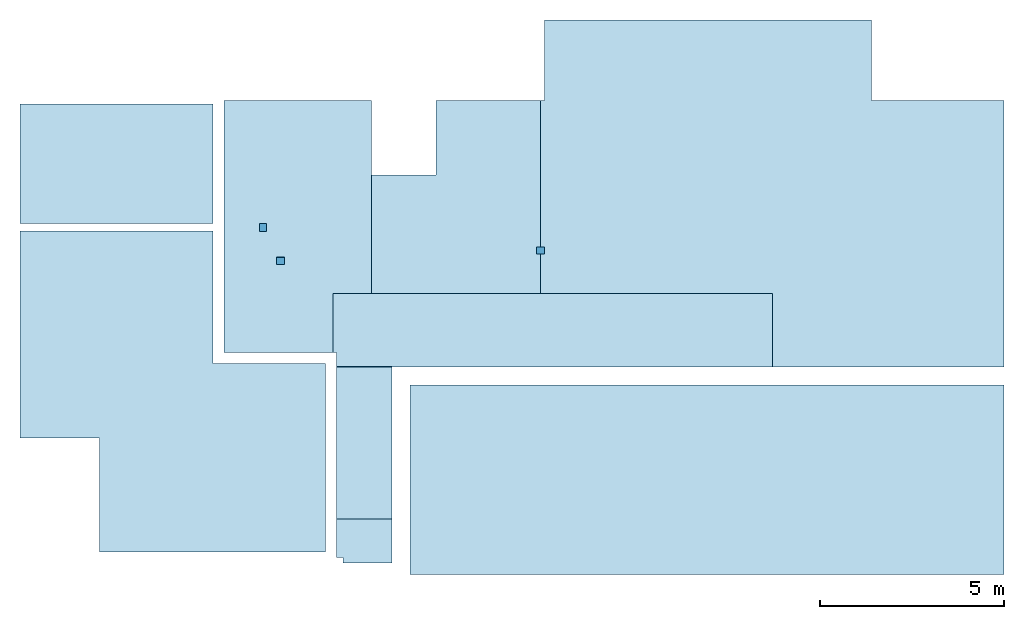
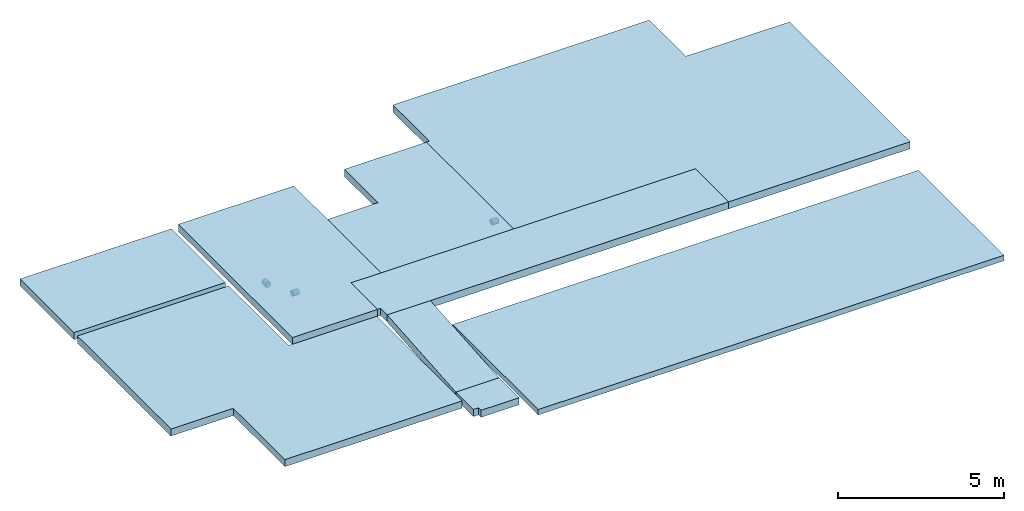
# One storey: 9 slabs, 3 beams, 12 elements without a shape of their own.
"""IFC2X3 building model written with IfcOpenShell, lengths in millimetres."""

import ifcopenshell
import ifcopenshell.guid

model = None  # the IFC model being written
_history = None  # IfcOwnerHistory: only IFC2X3 demands one
_inside = {}  # id of a spatial element -> (the spatial element, [elements in it])
_under = {}  # id of a project, library or spatial element -> (it, [spatial elements below it])
_declared = {}  # id of a project -> (the project, [libraries it declares])
_typed = {}  # id of a type object -> (the type object, [elements of that type])
_made_of = {}  # id of a material, layer set ... -> (it, [elements and type objects made of it])


def new_model(schema):
    """Start an empty IFC model of exactly this schema.

    Asked for "IFC4X3", IfcOpenShell would pick the latest addendum, in which some entities
    have other attributes; the version numbers below select the first issue.
    IFC2X3 requires an IfcOwnerHistory on every rooted entity: one is made here for all.
    """
    global model, _history
    if schema == "IFC4X3":
        model = ifcopenshell.file(schema_version=(4, 3, 0, 0))
    else:
        model = ifcopenshell.file(schema=schema)
    _inside.clear()
    _under.clear()
    _declared.clear()
    _typed.clear()
    _made_of.clear()
    _history = None
    if model.schema == "IFC2X3":
        org = make("IfcOrganization", Name="unknown")
        user = make(
            "IfcPersonAndOrganization",
            ThePerson=make("IfcPerson", FamilyName="unknown"),
            TheOrganization=org,
        )
        app = make(
            "IfcApplication",
            ApplicationDeveloper=org,
            Version="unknown",
            ApplicationFullName="unknown",
            ApplicationIdentifier="unknown",
        )
        _history = make(
            "IfcOwnerHistory",
            OwningUser=user,
            OwningApplication=app,
            ChangeAction="ADDED",
            CreationDate=0,
        )
    return model


def make(cls, **values):
    """One entity of the class cls with the attributes given. An attribute that is None is left unset."""
    return model.create_entity(
        cls, **{name: value for name, value in values.items() if value is not None}
    )


def rooted(cls, **values):
    """An entity with a GlobalId (a new one), such as an element, a storey or a relation."""
    return make(cls, GlobalId=ifcopenshell.guid.new(), OwnerHistory=_history, **values)


def si_unit(unit_type, name, prefix=None):
    """IfcSIUnit, for example si_unit("LENGTHUNIT", "METRE", prefix="MILLI")."""
    return make("IfcSIUnit", UnitType=unit_type, Prefix=prefix, Name=name)


def assignment(units):
    """IfcUnitAssignment: the units of a project."""
    return None if units is None else make("IfcUnitAssignment", Units=units)


def point(xyz):
    """IfcCartesianPoint."""
    return None if xyz is None else make("IfcCartesianPoint", Coordinates=xyz)


def direction(xyz):
    """IfcDirection."""
    return None if xyz is None else make("IfcDirection", DirectionRatios=xyz)


def frame(location, z_axis=None, x_axis=None):
    """IfcAxis2Placement3D, a coordinate frame: its origin and axes. An axis left out is left unset."""
    return make(
        "IfcAxis2Placement3D",
        Location=point(location),
        Axis=direction(z_axis),
        RefDirection=direction(x_axis),
    )


def origin_with_axes():
    """The frame at (0, 0, 0) with the z axis (0, 0, 1) and the x axis (1, 0, 0) written out."""
    return frame((0.0, 0.0, 0.0), z_axis=(0.0, 0.0, 1.0), x_axis=(1.0, 0.0, 0.0))


def place(relative_to, where):
    """IfcLocalPlacement: puts the frame where relative to a parent placement (None: the world)."""
    return make(
        "IfcLocalPlacement", PlacementRelTo=relative_to, RelativePlacement=where
    )


def context(
    kind, dimensions, precision=None, world=None, true_north=None, identifier=None
):
    """IfcGeometricRepresentationContext, for example the 3D "Model" context."""
    return make(
        "IfcGeometricRepresentationContext",
        ContextIdentifier=identifier,
        ContextType=kind,
        CoordinateSpaceDimension=dimensions,
        Precision=precision,
        WorldCoordinateSystem=world,
        TrueNorth=true_north,
    )


def subcontext(parent, identifier, kind, view, scale=None):
    """IfcGeometricRepresentationSubContext, for example "Body" below "Model"."""
    return make(
        "IfcGeometricRepresentationSubContext",
        ContextIdentifier=identifier,
        ContextType=kind,
        ParentContext=parent,
        TargetScale=scale,
        TargetView=view,
    )


def project(units=None, contexts=None):
    """IfcProject with its units and contexts."""
    return rooted(
        "IfcProject",
        Name="project",
        RepresentationContexts=contexts,
        UnitsInContext=assignment(units),
    )


def spatial(cls, under=None, at=None, **own):
    """A site, building, storey or space (cls), placed at a placement, below another one or the project."""
    s = rooted(cls, ObjectPlacement=at, **own)
    if under is not None:
        _under.setdefault(under.id(), (under, []))[1].append(s)
    return s


def faces_of(points, faces, orient=None, outer=None):
    """IfcFace entities. A face is a list of loops; a loop is a list of indices into points, from 0.

    orient and outer hold one flag for each loop. By default every Orientation is true, the
    first loop of a face is its IfcFaceOuterBound and the others are IfcFaceBound.
    """
    made = []
    for i, loops in enumerate(faces):
        bounds = []
        for j, loop in enumerate(loops):
            is_outer = j == 0 if outer is None else outer[i][j]
            bounds.append(
                make(
                    "IfcFaceOuterBound" if is_outer else "IfcFaceBound",
                    Bound=make("IfcPolyLoop", Polygon=[points[k] for k in loop]),
                    Orientation=True if orient is None else orient[i][j],
                )
            )
        made.append(make("IfcFace", Bounds=bounds))
    return made


def faceted_brep(points, faces, orient=None, outer=None, voids=None):
    """IfcFacetedBrep: a solid bounded by flat faces; with voids (closed shells), ...WithVoids."""
    shared = [point(p) for p in points]
    hull = make("IfcClosedShell", CfsFaces=faces_of(shared, faces, orient, outer))
    if voids is None:
        return make("IfcFacetedBrep", Outer=hull)
    return make(
        "IfcFacetedBrepWithVoids",
        Outer=hull,
        Voids=[
            make(cls, CfsFaces=faces_of(shared, fs, o, b)) for cls, fs, o, b in voids
        ],
    )


def shape(context_of_items, identifier, shape_type, items):
    """IfcShapeRepresentation: the items that make up one representation, for example the "Body"."""
    return make(
        "IfcShapeRepresentation",
        ContextOfItems=context_of_items,
        RepresentationIdentifier=identifier,
        RepresentationType=shape_type,
        Items=items,
    )


def material(Name=None, Category=None):
    """IfcMaterial."""
    return make("IfcMaterial", Name=Name, Category=Category)


def made_of(thing, what):
    """Note that an element or type object is made of a material, layer set ...; save() writes the relation."""
    if what is not None:
        _made_of.setdefault(what.id(), (what, []))[1].append(thing)
    return thing


def type_object(cls, material=None, **own):
    """A type object (cls), such as IfcWallType, which elements share."""
    return made_of(rooted(cls, **own), material)


def element(
    cls,
    number,
    at=None,
    inside=None,
    cuts=None,
    type_object=None,
    material=None,
    context=None,
    identifier="Body",
    shape_type=None,
    held_by="IfcProductDefinitionShape",
    body=None,
    shapes=None,
    **own,
):
    """One element of the class cls, such as IfcWall. Its Tag is "e" and its number.

    at: its placement. inside: the storey or other place that contains it. cuts: it is an
    opening in that element (IfcRelVoidsElement). A single representation is given by context,
    identifier, shape_type and body (its items); several are given by shapes. held_by: the class
    of the entity that holds the representations. save() writes the other relations.
    """
    e = rooted(cls, Tag="e%d" % number, ObjectPlacement=at, **own)
    if body is not None:
        shapes = [shape(context, identifier, shape_type, body)]
    if shapes is not None:
        e.Representation = make(held_by, Representations=shapes)
    if inside is not None:
        _inside.setdefault(inside.id(), (inside, []))[1].append(e)
    if cuts is not None:
        rooted(
            "IfcRelVoidsElement", RelatingBuildingElement=cuts, RelatedOpeningElement=e
        )
    if type_object is not None:
        _typed.setdefault(type_object.id(), (type_object, []))[1].append(e)
    return made_of(e, material)


def aggregate(whole, parts):
    """IfcRelAggregates: a whole, such as a stair, and the parts it consists of."""
    return rooted("IfcRelAggregates", RelatingObject=whole, RelatedObjects=parts)


def save(model, path):
    """Write the relations noted so far, then the file.

    IfcRelAggregates (storeys below a building ...), IfcRelContainedInSpatialStructure (elements
    in a storey), IfcRelDefinesByType, IfcRelAssociatesMaterial and IfcRelDeclares: one each for
    every whole, place, type object, material and project.
    """
    for whole, parts in _under.values():
        aggregate(whole, parts)
    for where, things in _inside.values():
        rooted(
            "IfcRelContainedInSpatialStructure",
            RelatedElements=things,
            RelatingStructure=where,
        )
    for kind, things in _typed.values():
        rooted("IfcRelDefinesByType", RelatedObjects=things, RelatingType=kind)
    for what, things in _made_of.values():
        rooted("IfcRelAssociatesMaterial", RelatedObjects=things, RelatingMaterial=what)
    for by, libraries in _declared.values():
        rooted("IfcRelDeclares", RelatingContext=by, RelatedDefinitions=libraries)
    model.write(path)


model = new_model("IFC2X3")

# Units and contexts
model_context = context("Model", 3, precision=1e-05, world=origin_with_axes())
body_context = subcontext(model_context, "Body", "Model", "MODEL_VIEW")
ifc_project = project(units=[si_unit("LENGTHUNIT", "METRE", prefix="MILLI"), si_unit("AREAUNIT", "SQUARE_METRE"), si_unit("VOLUMEUNIT", "CUBIC_METRE"), si_unit("MASSUNIT", "GRAM", prefix="KILO"), si_unit("TIMEUNIT", "SECOND"), si_unit("PLANEANGLEUNIT", "RADIAN"), si_unit("SOLIDANGLEUNIT", "STERADIAN"), si_unit("THERMODYNAMICTEMPERATUREUNIT", "DEGREE_CELSIUS"), si_unit("LUMINOUSINTENSITYUNIT", "LUMEN")], contexts=[model_context])

# Site, building, storey
site_placement = place(None, origin_with_axes())
site = spatial("IfcSite", under=ifc_project, at=site_placement, CompositionType="ELEMENT")
building_placement = place(site_placement, origin_with_axes())
building = spatial("IfcBuilding", under=site, at=building_placement, CompositionType="ELEMENT")
storey_placement = place(building_placement, origin_with_axes())
storey = spatial("IfcBuildingStorey", under=building, at=storey_placement, Name="P", CompositionType="ELEMENT", Elevation=0.0)

# Assembly, beam
assembly_1_placement = place(storey_placement, origin_with_axes())
assembly_1 = element("IfcElementAssembly", 1, at=assembly_1_placement, inside=storey, Name="Steel Assembly", AssemblyPlace="NOTDEFINED", PredefinedType="NOTDEFINED")
ifc_material_1 = material()
beam_type = type_object("IfcBeamType", Name="D200", PredefinedType="NOTDEFINED")
beam_1_placement = place(assembly_1_placement, frame((22200.3585037589, 16350.1445755362, 78320.0), z_axis=(0.0, 1.0, 0.0), x_axis=(1.0, 0.0, 0.0)))
beam_1 = element("IfcBeam", 2, at=beam_1_placement, type_object=beam_type, material=ifc_material_1, ObjectType="D200", context=body_context, shape_type="Brep", body=[
    faceted_brep([(0.0, -100.0, 0.0), (0.0, -96.5925826289022, -25.8819045102518), (219.641496241093, -96.5925826289022, -25.8819045102518), (219.641496241093, -100.0, 0.0), (0.0, -86.6025403784442, -50.0), (219.641496241093, -86.6025403784442, -50.0), (0.0, -70.7106781186594, -70.710678118654), (219.641496241093, -70.7106781186594, -70.710678118654), (0.0, -50.0, -86.6025403784442), (219.641496241093, -50.0, -86.6025403784442), (0.0, -25.8819045102573, -96.5925826289076), (219.641496241093, -25.8819045102573, -96.5925826289076), (0.0, 0.0, -100.0), (219.641496241093, 0.0, -100.0), (0.0, 25.8819045102573, -96.5925826289076), (219.641496241093, 25.8819045102573, -96.5925826289076), (0.0, 50.0, -86.6025403784442), (219.641496241093, 50.0, -86.6025403784442), (0.0, 70.7106781186594, -70.710678118654), (219.641496241093, 70.7106781186594, -70.710678118654), (0.0, 86.6025403784442, -50.0), (219.641496241093, 86.6025403784442, -50.0), (0.0, 96.5925826289022, -25.8819045102518), (219.641496241093, 96.5925826289022, -25.8819045102518), (0.0, 100.0, 0.0), (219.641496241093, 100.0, 0.0), (0.0, 96.5925826289022, 25.8819045102518), (219.641496241093, 96.5925826289022, 25.8819045102518), (0.0, 86.6025403784442, 50.0), (219.641496241093, 86.6025403784442, 50.0000000000018), (0.0, 70.7106781186594, 70.710678118654), (219.641496241093, 70.7106781186594, 70.710678118654), (0.0, 50.0, 86.6025403784442), (219.641496241093, 50.0, 86.6025403784424), (0.0, 25.8819045102573, 96.5925826289076), (219.641496241093, 25.8819045102573, 96.5925826289076), (0.0, 0.0, 100.0), (219.641496241093, 0.0, 100.000000000002), (0.0, -25.8819045102573, 96.5925826289076), (219.641496241093, -25.8819045102573, 96.5925826289076), (0.0, -50.0, 86.6025403784442), (219.641496241093, -50.0, 86.6025403784424), (0.0, -70.7106781186594, 70.710678118654), (219.641496241093, -70.7106781186594, 70.710678118654), (0.0, -86.6025403784442, 50.0), (219.641496241093, -86.6025403784442, 49.9999999999982), (0.0, -96.5925826289022, 25.8819045102518), (219.641496241093, -96.5925826289022, 25.8819045102518)], [[[0, 1, 2, 3]], [[1, 4, 5, 2]], [[4, 6, 7, 5]], [[6, 8, 9, 7]], [[8, 10, 11, 9]], [[10, 12, 13, 11]], [[12, 14, 15, 13]], [[14, 16, 17, 15]], [[16, 18, 19, 17]], [[18, 20, 21, 19]], [[20, 22, 23, 21]], [[22, 24, 25, 23]], [[24, 26, 27, 25]], [[26, 28, 29, 27]], [[28, 30, 31, 29]], [[30, 32, 33, 31]], [[32, 34, 35, 33]], [[34, 36, 37, 35]], [[36, 38, 39, 37]], [[38, 40, 41, 39]], [[40, 42, 43, 41]], [[42, 44, 45, 43]], [[44, 46, 47, 45]], [[46, 0, 3, 47]], [[5, 7, 9, 11, 13, 15, 17, 19, 21, 23, 25, 27, 29, 31, 33, 35, 37, 39, 41, 43, 45, 47, 3, 2]], [[46, 44, 42, 40, 38, 36, 34, 32, 30, 28, 26, 24, 22, 20, 18, 16, 14, 12, 10, 8, 6, 4, 1, 0]]]),
])
aggregate(assembly_1, [beam_1])

assembly_2_placement = place(storey_placement, origin_with_axes())
assembly_2 = element("IfcElementAssembly", 3, at=assembly_2_placement, inside=storey, Name="Steel Assembly", AssemblyPlace="NOTDEFINED", PredefinedType="NOTDEFINED")
beam_2_placement = place(assembly_2_placement, frame((14760.0000366569, 16869.9999222159, 78310.0), z_axis=(-1.0, 3.00000001838171e-08, 0.0), x_axis=(0.0, 1.0, 0.0)))
beam_2 = element("IfcBeam", 4, at=beam_2_placement, type_object=beam_type, material=ifc_material_1, ObjectType="D200", context=body_context, shape_type="Brep", body=[
    faceted_brep([(0.0, -100.0, 0.0), (0.0, -96.5925826289022, -25.8819045102518), (220.000077784061, -96.5925826289022, -25.8819045102518), (220.000077784061, -100.0, 0.0), (0.0, -86.6025403784442, -50.0), (220.000077784061, -86.6025403784442, -50.0), (0.0, -70.7106781186594, -70.710678118654), (220.000077784061, -70.7106781186594, -70.710678118654), (0.0, -50.0, -86.6025403784442), (220.000077784061, -50.0, -86.6025403784442), (0.0, -25.8819045102573, -96.5925826289076), (220.000077784061, -25.8819045102573, -96.5925826289076), (0.0, 0.0, -100.0), (220.000077784061, 0.0, -100.0), (0.0, 25.8819045102573, -96.5925826289076), (220.000077784061, 25.8819045102573, -96.5925826289076), (0.0, 50.0, -86.6025403784442), (220.000077784061, 50.0, -86.6025403784442), (0.0, 70.7106781186594, -70.710678118654), (220.000077784061, 70.7106781186594, -70.710678118654), (0.0, 86.6025403784442, -50.0), (220.000077784061, 86.6025403784442, -50.0), (0.0, 96.5925826289022, -25.8819045102518), (220.000077784061, 96.5925826289022, -25.8819045102518), (0.0, 100.0, 0.0), (220.000077784061, 100.0, 0.0), (0.0, 96.5925826289022, 25.8819045102518), (220.000077784061, 96.5925826289022, 25.8819045102518), (0.0, 86.6025403784442, 50.0), (220.000077784061, 86.6025403784442, 50.0), (0.0, 70.7106781186594, 70.710678118654), (220.000077784061, 70.7106781186594, 70.710678118654), (0.0, 50.0, 86.6025403784442), (220.000077784061, 50.0, 86.6025403784442), (0.0, 25.8819045102573, 96.5925826289076), (220.000077784061, 25.8819045102573, 96.5925826289076), (0.0, 0.0, 100.0), (220.000077784061, 0.0, 100.0), (0.0, -25.8819045102573, 96.5925826289076), (220.000077784061, -25.8819045102573, 96.5925826289076), (0.0, -50.0, 86.6025403784442), (220.000077784061, -50.0, 86.6025403784442), (0.0, -70.7106781186594, 70.710678118654), (220.000077784061, -70.7106781186594, 70.710678118654), (0.0, -86.6025403784442, 50.0), (220.000077784061, -86.6025403784442, 50.0), (0.0, -96.5925826289022, 25.8819045102518), (220.000077784061, -96.5925826289022, 25.8819045102518)], [[[0, 1, 2, 3]], [[1, 4, 5, 2]], [[4, 6, 7, 5]], [[6, 8, 9, 7]], [[8, 10, 11, 9]], [[10, 12, 13, 11]], [[12, 14, 15, 13]], [[14, 16, 17, 15]], [[16, 18, 19, 17]], [[18, 20, 21, 19]], [[20, 22, 23, 21]], [[22, 24, 25, 23]], [[24, 26, 27, 25]], [[26, 28, 29, 27]], [[28, 30, 31, 29]], [[30, 32, 33, 31]], [[32, 34, 35, 33]], [[34, 36, 37, 35]], [[36, 38, 39, 37]], [[38, 40, 41, 39]], [[40, 42, 43, 41]], [[42, 44, 45, 43]], [[44, 46, 47, 45]], [[46, 0, 3, 47]], [[5, 7, 9, 11, 13, 15, 17, 19, 21, 23, 25, 27, 29, 31, 33, 35, 37, 39, 41, 43, 45, 47, 3, 2]], [[46, 44, 42, 40, 38, 36, 34, 32, 30, 28, 26, 24, 22, 20, 18, 16, 14, 12, 10, 8, 6, 4, 1, 0]]]),
])
aggregate(assembly_2, [beam_2])

assembly_3_placement = place(storey_placement, origin_with_axes())
assembly_3 = element("IfcElementAssembly", 5, at=assembly_3_placement, inside=storey, Name="Steel Assembly", AssemblyPlace="NOTDEFINED", PredefinedType="NOTDEFINED")
beam_3_placement = place(assembly_3_placement, frame((15119.9999222159, 16070.0004562736, 78360.0), z_axis=(0.0, 1.0, 0.0), x_axis=(1.0, 0.0, 0.0)))
beam_3 = element("IfcBeam", 6, at=beam_3_placement, type_object=beam_type, material=ifc_material_1, ObjectType="D200", context=body_context, shape_type="Brep", body=[
    faceted_brep([(0.0, -100.0, 0.0), (0.0, -96.5925826289022, -25.8819045102518), (219.999809265137, -96.5925826289022, -25.8819045102518), (219.999809265137, -100.0, 0.0), (0.0, -86.6025403784442, -50.0), (219.999809265137, -86.6025403784442, -50.0), (0.0, -70.7106781186594, -70.710678118654), (219.999809265137, -70.7106781186594, -70.710678118654), (0.0, -50.0, -86.6025403784442), (219.999809265137, -50.0, -86.6025403784442), (0.0, -25.8819045102573, -96.5925826289076), (219.999809265137, -25.8819045102573, -96.5925826289076), (0.0, 0.0, -100.0), (219.999809265137, 0.0, -100.0), (0.0, 25.8819045102573, -96.5925826289076), (219.999809265137, 25.8819045102573, -96.5925826289076), (0.0, 50.0, -86.6025403784442), (219.999809265137, 50.0, -86.6025403784442), (0.0, 70.7106781186594, -70.710678118654), (219.999809265137, 70.7106781186594, -70.710678118654), (0.0, 86.6025403784442, -50.0), (219.999809265137, 86.6025403784442, -50.0), (0.0, 96.5925826289022, -25.8819045102518), (219.999809265137, 96.5925826289022, -25.8819045102518), (0.0, 100.0, 0.0), (219.999809265137, 100.0, 0.0), (0.0, 96.5925826289022, 25.8819045102518), (219.999809265137, 96.5925826289022, 25.8819045102518), (0.0, 86.6025403784442, 50.0), (219.999809265137, 86.6025403784442, 50.0), (0.0, 70.7106781186594, 70.710678118654), (219.999809265137, 70.7106781186594, 70.710678118654), (0.0, 50.0, 86.6025403784442), (219.999809265137, 50.0, 86.6025403784442), (0.0, 25.8819045102573, 96.5925826289076), (219.999809265137, 25.8819045102573, 96.5925826289076), (0.0, 0.0, 100.0), (219.999809265137, 0.0, 100.0), (0.0, -25.8819045102573, 96.5925826289076), (219.999809265137, -25.8819045102573, 96.5925826289076), (0.0, -50.0, 86.6025403784442), (219.999809265137, -50.0, 86.6025403784442), (0.0, -70.7106781186594, 70.710678118654), (219.999809265137, -70.7106781186594, 70.710678118654), (0.0, -86.6025403784442, 50.0), (219.999809265137, -86.6025403784442, 50.0), (0.0, -96.5925826289022, 25.8819045102518), (219.999809265137, -96.5925826289022, 25.8819045102518)], [[[0, 1, 2, 3]], [[1, 4, 5, 2]], [[4, 6, 7, 5]], [[6, 8, 9, 7]], [[8, 10, 11, 9]], [[10, 12, 13, 11]], [[12, 14, 15, 13]], [[14, 16, 17, 15]], [[16, 18, 19, 17]], [[18, 20, 21, 19]], [[20, 22, 23, 21]], [[22, 24, 25, 23]], [[24, 26, 27, 25]], [[26, 28, 29, 27]], [[28, 30, 31, 29]], [[30, 32, 33, 31]], [[32, 34, 35, 33]], [[34, 36, 37, 35]], [[36, 38, 39, 37]], [[38, 40, 41, 39]], [[40, 42, 43, 41]], [[42, 44, 45, 43]], [[44, 46, 47, 45]], [[46, 0, 3, 47]], [[5, 7, 9, 11, 13, 15, 17, 19, 21, 23, 25, 27, 29, 31, 33, 35, 37, 39, 41, 43, 45, 47, 3, 2]], [[46, 44, 42, 40, 38, 36, 34, 32, 30, 28, 26, 24, 22, 20, 18, 16, 14, 12, 10, 8, 6, 4, 1, 0]]]),
])
aggregate(assembly_3, [beam_3])

# Assembly, slab
assembly_4_placement = place(storey_placement, origin_with_axes())
assembly_4 = element("IfcElementAssembly", 7, at=assembly_4_placement, inside=storey, AssemblyPlace="NOTDEFINED", PredefinedType="REINFORCEMENT_UNIT")
ifc_material_2 = material(Name="CONCRETE/Concrete_Undefined")
slab_type_1 = type_object("IfcSlabType", PredefinedType="NOTDEFINED")
slab_1_placement = place(assembly_4_placement, frame((18749.9996017456, 12690.0000717712, 77900.0), z_axis=(1.0, 0.0, 0.0), x_axis=(0.0, -1.0, 0.0)))
slab_1 = element("IfcSlab", 8, at=slab_1_placement, type_object=slab_type_1, material=ifc_material_2, PredefinedType="FLOOR", context=body_context, shape_type="Brep", body=[
    faceted_brep([(0.0, -100.0, 0.0), (7.17712318873964e-05, -100.0, 16160.0), (7.17712318873964e-05, 100.0, 16160.0), (0.0, 100.0, 0.0), (5145.0, -100.0, 16160.0), (5145.0, 100.0, 16160.0), (5145.0, -100.0, 0.0), (5145.0, 100.0, 0.0)], [[[0, 1, 2, 3]], [[1, 4, 5, 2]], [[4, 6, 7, 5]], [[6, 0, 3, 7]], [[5, 7, 3, 2]], [[6, 4, 1, 0]]]),
])
aggregate(assembly_4, [slab_1])

assembly_5_placement = place(storey_placement, origin_with_axes())
assembly_5 = element("IfcElementAssembly", 9, at=assembly_5_placement, inside=storey, AssemblyPlace="NOTDEFINED", PredefinedType="REINFORCEMENT_UNIT")
slab_type_2 = type_object("IfcSlabType", PredefinedType="NOTDEFINED")
slab_2_placement = place(assembly_5_placement, frame((18259.9999526978, 9055.00033117064, 78290.0), z_axis=(0.0, -1.0, 0.0), x_axis=(-1.0, 3.00000001838171e-08, 0.0)))
slab_2 = element("IfcSlab", 10, at=slab_2_placement, type_object=slab_type_2, material=ifc_material_2, PredefinedType="FLOOR", context=body_context, shape_type="Brep", body=[
    faceted_brep([(1319.99995269776, -130.0, 1055.00026564057), (1319.99995269776, 130.0, 1055.00026564057), (1319.99995269776, 130.0, 1205.00036621094), (1319.99995269776, -130.0, 1205.00036621094), (1500.00012207031, -130.0, 1055.00026564057), (1500.00012207031, 130.0, 1055.00026564057), (1500.00012207031, -130.0, 0.0), (0.0, -130.0, -3.63797880709171e-12), (0.0, 130.0, -1.81898940354586e-12), (1500.00012207031, 130.0, 0.0), (-4.73009640700184e-05, -130.0, 1205.00036621094), (-4.73009640700184e-05, 130.0, 1205.00036621094)], [[[0, 1, 2, 3]], [[4, 5, 1, 0]], [[6, 7, 8, 9]], [[7, 10, 11, 8]], [[11, 10, 3, 2]], [[9, 8, 11, 2, 1, 5]], [[6, 9, 5, 4]], [[10, 7, 6, 4, 0, 3]]]),
])
aggregate(assembly_5, [slab_2])

assembly_6_placement = place(storey_placement, origin_with_axes())
assembly_6 = element("IfcElementAssembly", 11, at=assembly_6_placement, inside=storey, AssemblyPlace="NOTDEFINED", PredefinedType="REINFORCEMENT_UNIT")
slab_type_3 = type_object("IfcSlabType", PredefinedType="NOTDEFINED")
slab_3_placement = place(assembly_6_placement, frame((16759.9998308133, 13190.3667230055, 78620.4140138876), z_axis=(1.0, 0.0, 0.0), x_axis=(0.0, -0.99681527776029, -0.0797452319808236)))
slab_3 = element("IfcSlab", 12, at=slab_3_placement, type_object=slab_type_3, material=ifc_material_2, PredefinedType="FLOOR", context=body_context, shape_type="Brep", body=[
    faceted_brep([(0.0, -130.0, -3.63797880709171e-12), (2.70353884843644e-05, -130.0, 1500.00024414063), (2.70353884843644e-05, 130.000000000015, 1500.00024414063), (0.0, 130.0, -1.81898940354586e-12), (4138.17822277587, -130.0, 1500.00012207031), (4138.17822277586, 130.0, 1500.00012207031), (4138.17822265625, -130.0, -3.30328475683928e-09), (4138.17822265625, 130.000000000015, -3.30328475683928e-09)], [[[0, 1, 2, 3]], [[1, 4, 5, 2]], [[4, 6, 7, 5]], [[6, 0, 3, 7]], [[5, 7, 3, 2]], [[6, 4, 1, 0]]]),
])
aggregate(assembly_6, [slab_3])

assembly_7_placement = place(storey_placement, origin_with_axes())
assembly_7 = element("IfcElementAssembly", 13, at=assembly_7_placement, inside=storey, AssemblyPlace="NOTDEFINED", PredefinedType="REINFORCEMENT_UNIT")
slab_type_4 = type_object("IfcSlabType", PredefinedType="NOTDEFINED")
slab_4_placement = place(assembly_7_placement, frame((22310.0, 15180.0, 78620.0), z_axis=(0.0, 1.0, 0.0), x_axis=(1.0, 0.0, 0.0)))
slab_4 = element("IfcSlab", 14, at=slab_4_placement, type_object=slab_type_4, material=ifc_material_2, PredefinedType="FLOOR", context=body_context, shape_type="Brep", body=[
    faceted_brep([(0.0, -130.0, -3.63797880709171e-12), (0.0, -130.0, 5250.0), (0.0, 130.0, 5250.0), (0.0, 130.0, -1.81898940354586e-12), (99.9994049072266, -130.0, 5250.0), (99.9994049072266, 130.0, 5250.0), (99.9994049072266, -130.0, 7440.0), (99.9994049072266, 130.0, 7440.0), (8999.9951171875, -130.0, 7440.0), (8999.9951171875, 130.0, 7440.0), (8999.9951171875, -130.0, 5250.0), (8999.9951171875, 130.0, 5250.0), (12600.0029296875, -130.0, 5250.0), (12600.0029296875, 130.0, 5250.0), (12600.0029296875, -130.0, -1999.998046875), (12600.0029296875, 130.0, -1999.998046875), (6300.0, -130.0, -2000.00036621094), (6300.0, 130.0, -2000.00036621094), (6300.0, -130.0, 0.0), (6300.0, 130.0, 0.0)], [[[0, 1, 2, 3]], [[1, 4, 5, 2]], [[4, 6, 7, 5]], [[6, 8, 9, 7]], [[8, 10, 11, 9]], [[10, 12, 13, 11]], [[12, 14, 15, 13]], [[14, 16, 17, 15]], [[16, 18, 19, 17]], [[18, 0, 3, 19]], [[5, 7, 9, 11, 13, 15, 17, 19, 3, 2]], [[18, 16, 14, 12, 10, 8, 6, 4, 1, 0]]]),
])
aggregate(assembly_7, [slab_4])

assembly_8_placement = place(storey_placement, origin_with_axes())
assembly_8 = element("IfcElementAssembly", 15, at=assembly_8_placement, inside=storey, AssemblyPlace="NOTDEFINED", PredefinedType="REINFORCEMENT_UNIT")
slab_type_5 = type_object("IfcSlabType", PredefinedType="NOTDEFINED")
slab_5_placement = place(assembly_8_placement, frame((16759.9998306274, 13179.9998428894, 78620.0), z_axis=(0.0, 1.0, 0.0), x_axis=(1.0, 0.0, 0.0)))
slab_5 = element("IfcSlab", 16, at=slab_5_placement, type_object=slab_type_5, material=ifc_material_2, PredefinedType="FLOOR", context=body_context, shape_type="Brep", body=[
    faceted_brep([(0.0, -130.0, -3.63797880709171e-12), (0.00109354115556926, -130.0, 395.000152587891), (0.00109354115556926, 130.0, 395.000152587891), (0.0, 130.0, -1.81898940354586e-12), (-99.9998397827185, -130.0, 395.000274658205), (-99.9998397827185, 130.0, 395.000274658205), (-99.999870300293, -130.0, 2000.00012207031), (-99.999870300293, 130.0, 2000.00012207031), (11850.0, -130.0, 2000.00036621094), (11850.0, 130.0, 2000.00036621094), (11850.0, -130.0, 6.82121026329696e-10), (11850.0, 130.0, 6.82121026329696e-10)], [[[0, 1, 2, 3]], [[1, 4, 5, 2]], [[4, 6, 7, 5]], [[6, 8, 9, 7]], [[8, 10, 11, 9]], [[10, 0, 3, 11]], [[5, 7, 9, 11, 3, 2]], [[10, 8, 6, 4, 1, 0]]]),
])
aggregate(assembly_8, [slab_5])

assembly_9_placement = place(storey_placement, origin_with_axes())
assembly_9 = element("IfcElementAssembly", 17, at=assembly_9_placement, inside=storey, AssemblyPlace="NOTDEFINED", PredefinedType="REINFORCEMENT_UNIT")
slab_type_6 = type_object("IfcSlabType", PredefinedType="NOTDEFINED")
slab_6_placement = place(assembly_9_placement, frame((17710.0, 15180.0, 78620.0), z_axis=(0.0, 1.0, 0.0), x_axis=(1.0, 0.0, 0.0)))
slab_6 = element("IfcSlab", 18, at=slab_6_placement, type_object=slab_type_6, material=ifc_material_2, PredefinedType="FLOOR", context=body_context, shape_type="Brep", body=[
    faceted_brep([(0.0, -130.0, -3.63797880709171e-12), (0.0, -130.0, 3229.99926757813), (0.0, 130.0, 3229.99926757813), (0.0, 130.0, -1.81898940354586e-12), (1749.99963378906, -130.0, 3229.99926757813), (1749.99963378906, 130.0, 3229.99926757813), (1750.00036621094, -130.0, 5250.00048828125), (1750.00036621094, 130.0, 5250.00048828125), (4600.0, -130.0, 5250.0), (4600.0, 130.0, 5250.0), (4600.0, -130.0, 0.0), (4600.0, 130.0, 0.0)], [[[0, 1, 2, 3]], [[1, 4, 5, 2]], [[4, 6, 7, 5]], [[6, 8, 9, 7]], [[8, 10, 11, 9]], [[10, 0, 3, 11]], [[5, 7, 9, 11, 3, 2]], [[10, 8, 6, 4, 1, 0]]]),
])
aggregate(assembly_9, [slab_6])

assembly_10_placement = place(storey_placement, origin_with_axes())
assembly_10 = element("IfcElementAssembly", 19, at=assembly_10_placement, inside=storey, AssemblyPlace="NOTDEFINED", PredefinedType="REINFORCEMENT_UNIT")
slab_type_7 = type_object("IfcSlabType", PredefinedType="NOTDEFINED")
slab_7_placement = place(assembly_10_placement, frame((13700.0033728411, 13575.0031172879, 78620.0), z_axis=(1.00999999995059e-06, 0.99999999999949, 0.0), x_axis=(0.999999999999375, -1.11799999997436e-06, 0.0)))
slab_7 = element("IfcSlab", 20, at=slab_7_placement, type_object=slab_type_7, material=ifc_material_2, PredefinedType="FLOOR", context=body_context, shape_type="Brep", body=[
    faceted_brep([(0.0, -130.0, -3.63797880709171e-12), (-0.00692170904767409, -130.0, 6854.9970703125), (-0.00692170904767409, 130.0, 6854.9970703125), (0.0, 130.0, -1.81898940354586e-12), (4009.98974609375, -130.0, 6855.0009765625), (4009.98974609375, 130.0, 6855.0009765625), (4009.9951171875, -130.0, 1605.0009765625), (4009.9951171875, 130.0, 1605.0009765625), (2959.9951171875, -130.0, 1604.99987792969), (2959.9951171875, 130.0, 1604.99987792969), (2959.99658203125, -130.0, 2.48110154643655e-09), (2959.99658203125, 130.0, 2.48110154643655e-09)], [[[0, 1, 2, 3]], [[1, 4, 5, 2]], [[4, 6, 7, 5]], [[6, 8, 9, 7]], [[8, 10, 11, 9]], [[10, 0, 3, 11]], [[5, 7, 9, 11, 3, 2]], [[10, 8, 6, 4, 1, 0]]]),
])
aggregate(assembly_10, [slab_7])

assembly_11_placement = place(storey_placement, origin_with_axes())
assembly_11 = element("IfcElementAssembly", 21, at=assembly_11_placement, inside=storey, AssemblyPlace="NOTDEFINED", PredefinedType="REINFORCEMENT_UNIT")
slab_type_8 = type_object("IfcSlabType", PredefinedType="NOTDEFINED")
slab_8_placement = place(assembly_11_placement, frame((13400.0003210833, 20330.0003707059, 78620.0), z_axis=(0.0, -1.0, 0.0), x_axis=(-1.0, 3.00000001838171e-08, 0.0)))
slab_8 = element("IfcSlab", 22, at=slab_8_placement, type_object=slab_type_8, material=ifc_material_2, PredefinedType="FLOOR", context=body_context, shape_type="Brep", body=[
    faceted_brep([(0.0, -130.0, -3.63797880709171e-12), (0.0, -130.0, 3249.9970703125), (0.0, 130.0, 3249.9970703125), (0.0, 130.0, -1.81898940354586e-12), (5250.0, -130.0, 3249.9970703125), (5250.0, 130.0, 3249.9970703125), (5250.0, -130.0, 0.0), (5250.0, 130.0, 0.0)], [[[0, 1, 2, 3]], [[1, 4, 5, 2]], [[4, 6, 7, 5]], [[6, 0, 3, 7]], [[5, 7, 3, 2]], [[6, 4, 1, 0]]]),
])
aggregate(assembly_11, [slab_8])

assembly_12_placement = place(storey_placement, origin_with_axes())
assembly_12 = element("IfcElementAssembly", 23, at=assembly_12_placement, inside=storey, AssemblyPlace="NOTDEFINED", PredefinedType="REINFORCEMENT_UNIT")
slab_type_9 = type_object("IfcSlabType", PredefinedType="NOTDEFINED")
slab_9_placement = place(assembly_12_placement, frame((13400.0003210833, 16880.0034224637, 78620.0), z_axis=(0.0, -1.0, 0.0), x_axis=(-1.0, 3.00000001838171e-08, 0.0)))
slab_9 = element("IfcSlab", 24, at=slab_9_placement, type_object=slab_type_9, material=ifc_material_2, PredefinedType="FLOOR", context=body_context, shape_type="Brep", body=[
    faceted_brep([(0.0, -130.0, -3.63797880709171e-12), (0.0, -130.0, 3605.00341796875), (0.0, 130.0, 3605.00341796875), (0.0, 130.0, -1.81898940354586e-12), (-3060.00048828125, -130.0, 3605.00341796875), (-3060.00048828125, 130.0, 3605.00341796875), (-3060.00048828125, -130.0, 8730.0068359375), (-3060.00048828125, 130.0, 8730.0068359375), (3089.99633789063, -130.0, 8730.0029296875), (3089.99633789063, 130.0, 8730.0029296875), (3089.99633789063, -130.0, 5630.0048828125), (3089.99633789063, 130.0, 5630.0048828125), (5250.0, -130.0, 5630.0048828125), (5250.0, 130.0, 5630.0048828125), (5250.0, -130.0, 0.0), (5250.0, 130.0, 0.0)], [[[0, 1, 2, 3]], [[1, 4, 5, 2]], [[4, 6, 7, 5]], [[6, 8, 9, 7]], [[8, 10, 11, 9]], [[10, 12, 13, 11]], [[12, 14, 15, 13]], [[14, 0, 3, 15]], [[5, 7, 9, 11, 13, 15, 3, 2]], [[14, 12, 10, 8, 6, 4, 1, 0]]]),
])
aggregate(assembly_12, [slab_9])

save(model, "model.ifc")
